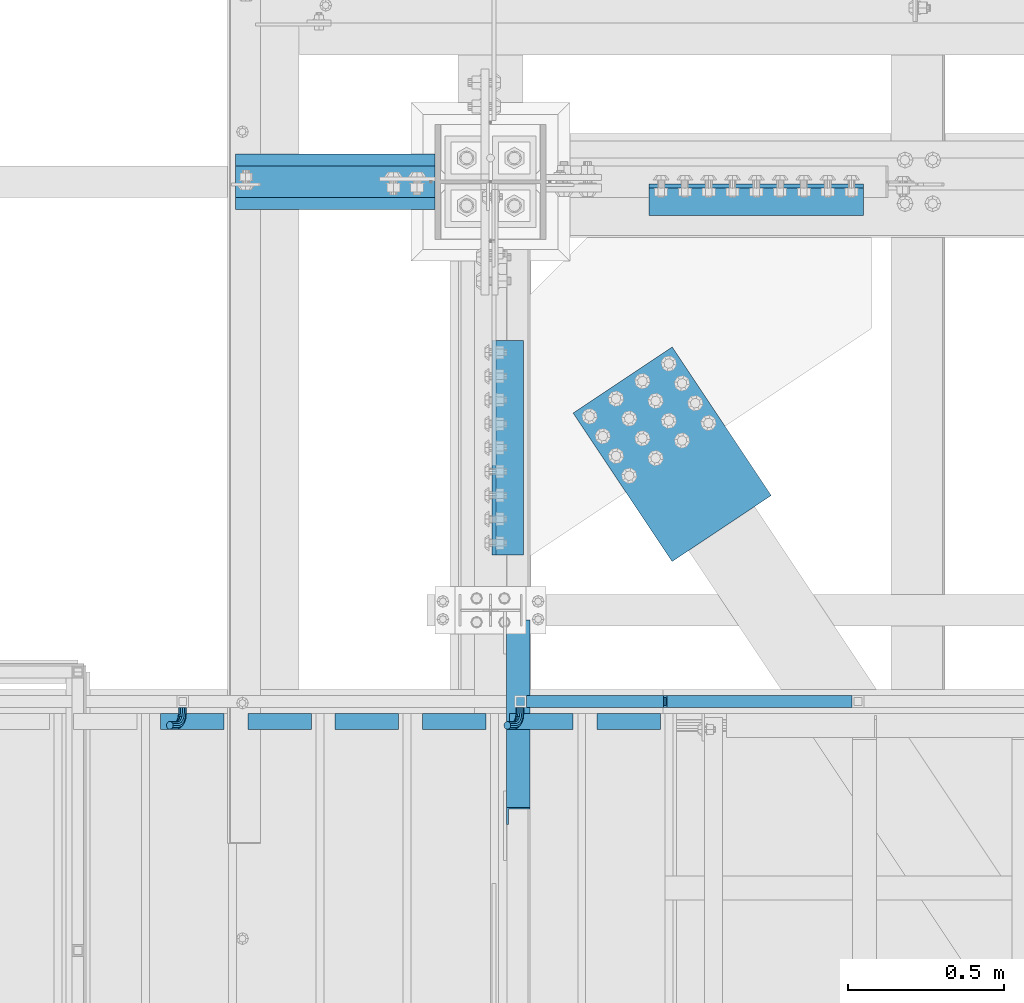
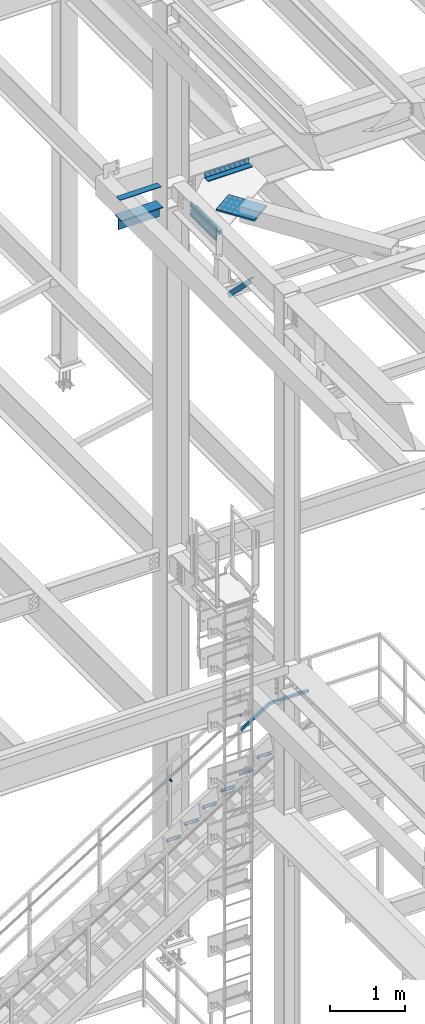
# One storey, part 2417 of 3843: 15 beams, 2 members, 7 elements without a shape of their own.
"""IFC2X3 building model written with IfcOpenShell, lengths in millimetres."""

from ifc_helpers import new_model, si_unit, frame, origin_with_axes, place, context, subcontext, project, spatial, faceted_brep, material, type_object, element, aggregate, save


model = new_model("IFC2X3")

# Units and contexts
model_context = context("Model", 3, precision=1e-05, world=origin_with_axes())
body_context = subcontext(model_context, "Body", "Model", "MODEL_VIEW")
ifc_project = project(units=[si_unit("LENGTHUNIT", "METRE", prefix="MILLI"), si_unit("AREAUNIT", "SQUARE_METRE"), si_unit("VOLUMEUNIT", "CUBIC_METRE"), si_unit("MASSUNIT", "GRAM", prefix="KILO"), si_unit("TIMEUNIT", "SECOND"), si_unit("PLANEANGLEUNIT", "RADIAN"), si_unit("SOLIDANGLEUNIT", "STERADIAN"), si_unit("THERMODYNAMICTEMPERATUREUNIT", "DEGREE_CELSIUS"), si_unit("LUMINOUSINTENSITYUNIT", "LUMEN")], contexts=[model_context])

# Site, building, storey
site_placement = place(None, origin_with_axes())
site = spatial("IfcSite", under=ifc_project, at=site_placement, CompositionType="ELEMENT")
building_placement = place(site_placement, origin_with_axes())
building = spatial("IfcBuilding", under=site, at=building_placement, Name="Undefined", CompositionType="ELEMENT")
storey_placement = place(building_placement, origin_with_axes())
storey = spatial("IfcBuildingStorey", under=building, at=storey_placement, Name="Undefined", CompositionType="ELEMENT", Elevation=0.0)

# Assembly, beam, member
assembly_1_placement = place(storey_placement, origin_with_axes())
assembly_1 = element("IfcElementAssembly", 1, at=assembly_1_placement, inside=storey, Name="RAIL", AssemblyPlace="NOTDEFINED", PredefinedType="RIGID_FRAME")
ifc_material_1 = material()
beam_type_1 = type_object("IfcBeamType", Name="HSS1-1/2X1-1/2X1/4", PredefinedType="NOTDEFINED")
beam_1_placement = place(assembly_1_placement, frame((37134.8000002412, 90551.0000000455, 34670.9999996949), z_axis=(0.0, 0.0, 1.0), x_axis=(1.0, 0.0, 0.0)))
beam_1 = element("IfcBeam", 2, at=beam_1_placement, type_object=beam_type_1, material=ifc_material_1, Name="RAIL", ObjectType="HSS1-1/2X1-1/2X1/4", context=body_context, shape_type="Brep", body=[
    faceted_brep([(598.714285670809, -19.0500000000029, 19.0499992350015), (598.714285670809, -19.0499992349942, -19.0499992350015), (598.714285670809, 19.0499992349942, -19.0499992350015), (598.714285670809, 19.0499992349942, 19.0499992350015), (598.714285670809, -12.6999993299978, 12.6999993299978), (598.714285670809, 12.6999993299978, 12.6999993299978), (598.714285670809, 12.6999993299978, -12.6999993299978), (598.714285670809, -12.6999993299978, -12.6999993299978), (-5.45142736178605, 19.0499992350015, 19.0499992350015), (-5.45142736178605, -19.0499992350015, 19.0499992350015), (5.45142728947758, -19.0499992350015, -19.0499992350015), (5.45142728947758, 19.0499992350015, -19.0499992350015), (-3.63428487412239, 12.6999993299978, 12.6999993299978), (-3.63428487412239, -12.6999993299978, 12.6999993299978), (3.63428480181392, -12.6999993299978, -12.6999993299978), (3.63428480181392, 12.6999993299978, -12.6999993299978)], [[[0, 1, 2, 3], [4, 5, 6, 7]], [[8, 9, 0, 3]], [[10, 11, 2, 1]], [[9, 10, 1, 0]], [[11, 8, 3, 2]], [[10, 9, 8, 11], [12, 13, 14, 15]], [[14, 13, 4, 7]], [[15, 14, 7, 6]], [[12, 15, 6, 5]], [[13, 12, 5, 4]]]),
])
member_type_1 = type_object("IfcMemberType", Name="HSS1-1/2X1-1/2X1/4", PredefinedType="NOTDEFINED")
member_1_placement = place(assembly_1_placement, frame((36671.7035715726, 90551.0000000455, 34382.3165117603), z_axis=(-0.529007926750979, 0.0, 0.848616882600523), x_axis=(0.848616882600527, 0.0, 0.529007926750974)))
member_1 = element("IfcMember", 3, at=member_1_placement, type_object=member_type_1, material=ifc_material_1, Name="RAIL", ObjectType="HSS1-1/2X1-1/2X1/4", context=body_context, shape_type="Brep", body=[
    faceted_brep([(34.3236166958304, -19.0500000222455, 19.0499992349305), (34.3236166958304, 19.0499992350015, 19.0499992349305), (10.5729683018217, 19.0499992350015, -19.0499992349742), (10.5729683018217, -19.0499992350015, -19.0499992349742), (30.3651751973375, -12.6999993299978, 12.6999993299451), (14.5314098008821, -12.6999993299978, -12.6999993299924), (14.5314098008821, 12.6999993299978, -12.6999993299924), (30.3651751973375, 12.6999993299978, 12.6999993299451), (540.255873788832, 19.0499992349942, -19.049999234514), (540.255873788832, -19.0499992349942, -19.049999234514), (551.158728464914, -19.0499992349942, 19.0499992354125), (551.158728464914, 19.0499992349942, 19.0499992354125), (549.341585973118, -12.6999993299978, 12.6999993304307), (549.341585973118, 12.6999993299978, 12.6999993304307), (542.073016280629, 12.6999993299978, -12.6999993295285), (542.073016280629, -12.6999993299978, -12.6999993295285)], [[[0, 1, 2, 3], [4, 5, 6, 7]], [[8, 9, 3, 2]], [[9, 10, 0, 3]], [[10, 11, 1, 0]], [[11, 8, 2, 1]], [[10, 9, 8, 11], [12, 13, 14, 15]], [[13, 12, 4, 7]], [[14, 13, 7, 6]], [[15, 14, 6, 5]], [[12, 15, 5, 4]]]),
])

# Assembly, beams
assembly_2_placement = place(storey_placement, origin_with_axes())
assembly_2 = element("IfcElementAssembly", 4, at=assembly_2_placement, inside=storey, Name="STAIR", AssemblyPlace="NOTDEFINED", PredefinedType="RIGID_FRAME")
ifc_material_2 = material(Name="STEEL/A36")
beam_type_2 = type_object("IfcBeamType", Name="L2X2X3/16", PredefinedType="NOTDEFINED")
beam_2_placement = place(assembly_2_placement, frame((36916.8169176754, 90487.500000018, 33884.0535714322), z_axis=(0.0, -1.0, 0.0), x_axis=(1.0, 0.0, 0.0)))
beam_2 = element("IfcBeam", 5, at=beam_2_placement, type_object=beam_type_2, material=ifc_material_2, Name="ANGLE", ObjectType="L2X2X3/16", context=body_context, shape_type="Brep", body=[
    faceted_brep([(0.0, 25.4000000000015, -25.4000000000015), (0.0, 25.4000000000015, 25.4000000000015), (203.199999999997, 25.4000000000015, 25.4000000000015), (203.199999999997, 25.4000000000015, -25.4000000000015), (0.0, 20.6375000000007, 25.4000000000015), (203.199999999997, 20.6375000000007, 25.4000000000015), (0.0, 20.6375000000007, -20.6375000000007), (203.199999999997, 20.6375000000007, -20.6375000000007), (0.0, -25.4000000000015, -20.6375000000007), (203.199999999997, -25.4000000000015, -20.6375000000007), (0.0, -25.4000000000015, -25.4000000000015), (203.199999999997, -25.4000000000015, -25.4000000000015)], [[[0, 1, 2, 3]], [[1, 4, 5, 2]], [[4, 6, 7, 5]], [[6, 8, 9, 7]], [[8, 10, 11, 9]], [[10, 0, 3, 11]], [[5, 7, 9, 11, 3, 2]], [[10, 8, 6, 4, 1, 0]]]),
])
beam_3_placement = place(assembly_2_placement, frame((36637.4169176732, 90487.4999999996, 33709.8821428615), z_axis=(0.0, -1.0, 0.0), x_axis=(1.0, 0.0, 0.0)))
beam_3 = element("IfcBeam", 6, at=beam_3_placement, type_object=beam_type_2, material=ifc_material_2, Name="ANGLE", ObjectType="L2X2X3/16", context=body_context, shape_type="Brep", body=[
    faceted_brep([(0.0, 25.4000000000015, -25.4000000000015), (0.0, 25.4000000000015, 25.4000000000015), (203.199999999997, 25.4000000000015, 25.4000000000015), (203.199999999997, 25.4000000000015, -25.4000000000015), (0.0, 20.6375000000007, 25.4000000000015), (203.199999999997, 20.6375000000007, 25.4000000000015), (0.0, 20.6375000000007, -20.6375000000007), (203.199999999997, 20.6375000000007, -20.6375000000007), (0.0, -25.4000000000015, -20.6375000000007), (203.199999999997, -25.4000000000015, -20.6375000000007), (0.0, -25.4000000000015, -25.4000000000015), (203.199999999997, -25.4000000000015, -25.4000000000015)], [[[0, 1, 2, 3]], [[1, 4, 5, 2]], [[4, 6, 7, 5]], [[6, 8, 9, 7]], [[8, 10, 11, 9]], [[10, 0, 3, 11]], [[5, 7, 9, 11, 3, 2]], [[10, 8, 6, 4, 1, 0]]]),
])
beam_4_placement = place(assembly_2_placement, frame((36358.0169176732, 90487.4999999996, 33535.71071429), z_axis=(0.0, -1.0, 0.0), x_axis=(1.0, 0.0, 0.0)))
beam_4 = element("IfcBeam", 7, at=beam_4_placement, type_object=beam_type_2, material=ifc_material_2, Name="ANGLE", ObjectType="L2X2X3/16", context=body_context, shape_type="Brep", body=[
    faceted_brep([(0.0, 25.4000000000015, -25.4000000000015), (0.0, 25.4000000000015, 25.4000000000015), (203.199999999997, 25.4000000000015, 25.4000000000015), (203.199999999997, 25.4000000000015, -25.4000000000015), (0.0, 20.6375000000007, 25.4000000000015), (203.199999999997, 20.6375000000007, 25.4000000000015), (0.0, 20.6375000000007, -20.6375000000007), (203.199999999997, 20.6375000000007, -20.6375000000007), (0.0, -25.4000000000015, -20.6375000000007), (203.199999999997, -25.4000000000015, -20.6375000000007), (0.0, -25.4000000000015, -25.4000000000015), (203.199999999997, -25.4000000000015, -25.4000000000015)], [[[0, 1, 2, 3]], [[1, 4, 5, 2]], [[4, 6, 7, 5]], [[6, 8, 9, 7]], [[8, 10, 11, 9]], [[10, 0, 3, 11]], [[5, 7, 9, 11, 3, 2]], [[10, 8, 6, 4, 1, 0]]]),
])
beam_5_placement = place(assembly_2_placement, frame((36078.6169176732, 90487.4999999996, 33361.5392857186), z_axis=(0.0, -1.0, 0.0), x_axis=(1.0, 0.0, 0.0)))
beam_5 = element("IfcBeam", 8, at=beam_5_placement, type_object=beam_type_2, material=ifc_material_2, Name="ANGLE", ObjectType="L2X2X3/16", context=body_context, shape_type="Brep", body=[
    faceted_brep([(0.0, 25.4000000000015, -25.4000000000015), (0.0, 25.4000000000015, 25.4000000000015), (203.199999999997, 25.4000000000015, 25.4000000000015), (203.199999999997, 25.4000000000015, -25.4000000000015), (0.0, 20.6375000000007, 25.4000000000015), (203.199999999997, 20.6375000000007, 25.4000000000015), (0.0, 20.6375000000007, -20.6375000000007), (203.199999999997, 20.6375000000007, -20.6375000000007), (0.0, -25.4000000000015, -20.6375000000007), (203.199999999997, -25.4000000000015, -20.6375000000007), (0.0, -25.4000000000015, -25.4000000000015), (203.199999999997, -25.4000000000015, -25.4000000000015)], [[[0, 1, 2, 3]], [[1, 4, 5, 2]], [[4, 6, 7, 5]], [[6, 8, 9, 7]], [[8, 10, 11, 9]], [[10, 0, 3, 11]], [[5, 7, 9, 11, 3, 2]], [[10, 8, 6, 4, 1, 0]]]),
])
beam_6_placement = place(assembly_2_placement, frame((35799.2169176732, 90487.4999999996, 33187.3678571472), z_axis=(0.0, -1.0, 0.0), x_axis=(1.0, 0.0, 0.0)))
beam_6 = element("IfcBeam", 9, at=beam_6_placement, type_object=beam_type_2, material=ifc_material_2, Name="ANGLE", ObjectType="L2X2X3/16", context=body_context, shape_type="Brep", body=[
    faceted_brep([(0.0, 25.4000000000015, -25.4000000000015), (0.0, 25.4000000000015, 25.4000000000015), (203.199999999997, 25.4000000000015, 25.4000000000015), (203.199999999997, 25.4000000000015, -25.4000000000015), (0.0, 20.6375000000007, 25.4000000000015), (203.199999999997, 20.6375000000007, 25.4000000000015), (0.0, 20.6375000000007, -20.6375000000007), (203.199999999997, 20.6375000000007, -20.6375000000007), (0.0, -25.4000000000015, -20.6375000000007), (203.199999999997, -25.4000000000015, -20.6375000000007), (0.0, -25.4000000000015, -25.4000000000015), (203.199999999997, -25.4000000000015, -25.4000000000015)], [[[0, 1, 2, 3]], [[1, 4, 5, 2]], [[4, 6, 7, 5]], [[6, 8, 9, 7]], [[8, 10, 11, 9]], [[10, 0, 3, 11]], [[5, 7, 9, 11, 3, 2]], [[10, 8, 6, 4, 1, 0]]]),
])
beam_7_placement = place(assembly_2_placement, frame((35519.8169176732, 90487.4999999996, 33013.1964285758), z_axis=(0.0, -1.0, 0.0), x_axis=(1.0, 0.0, 0.0)))
beam_7 = element("IfcBeam", 10, at=beam_7_placement, type_object=beam_type_2, material=ifc_material_2, Name="ANGLE", ObjectType="L2X2X3/16", context=body_context, shape_type="Brep", body=[
    faceted_brep([(0.0, 25.4000000000015, -25.4000000000015), (0.0, 25.4000000000015, 25.4000000000015), (203.199999999997, 25.4000000000015, 25.4000000000015), (203.199999999997, 25.4000000000015, -25.4000000000015), (0.0, 20.6375000000007, 25.4000000000015), (203.199999999997, 20.6375000000007, 25.4000000000015), (0.0, 20.6375000000007, -20.6375000000007), (203.199999999997, 20.6375000000007, -20.6375000000007), (0.0, -25.4000000000015, -20.6375000000007), (203.199999999997, -25.4000000000015, -20.6375000000007), (0.0, -25.4000000000015, -25.4000000000015), (203.199999999997, -25.4000000000015, -25.4000000000015)], [[[0, 1, 2, 3]], [[1, 4, 5, 2]], [[4, 6, 7, 5]], [[6, 8, 9, 7]], [[8, 10, 11, 9]], [[10, 0, 3, 11]], [[5, 7, 9, 11, 3, 2]], [[10, 8, 6, 4, 1, 0]]]),
])
aggregate(assembly_2, [beam_2, beam_3, beam_4, beam_5, beam_6, beam_7])

# Assembly, beam
assembly_3_placement = place(storey_placement, origin_with_axes())
assembly_3 = element("IfcElementAssembly", 11, at=assembly_3_placement, inside=storey, Name="COLUMN", AssemblyPlace="NOTDEFINED", PredefinedType="RIGID_FRAME")
ifc_material_3 = material(Name="STEEL/A992")
beam_type_3 = type_object("IfcBeamType", Name="WT8X18", PredefinedType="NOTDEFINED")
beam_8_placement = place(assembly_3_placement, frame((35760.025, 92214.7, 41962.3875), z_axis=(0.0, 0.0, 1.0), x_axis=(1.0, 0.0, 0.0)))
beam_8 = element("IfcBeam", 12, at=beam_8_placement, type_object=beam_type_3, material=ifc_material_3, Name="BEAM", ObjectType="WT8X18", context=body_context, shape_type="Brep", body=[
    faceted_brep([(-1.45519152283669e-11, 3.96875, -100.012499999997), (-1.45519152283669e-11, 3.96875, 88.9000000000015), (638.175000000003, 3.96875, 88.9000000000015), (638.175000000003, 3.96875, -100.012499999997), (-2.18278728425503e-10, 88.8999999999942, 88.9000000000015), (638.175000000003, 88.9000000000015, 88.9000000000015), (-2.18278728425503e-10, 88.8999999999942, 100.012499999997), (638.175000000003, 88.9000000000015, 100.012499999997), (2.03726813197136e-10, -88.8999999999942, 100.012499999997), (638.175000000003, -88.9000000000015, 100.012499999997), (2.03726813197136e-10, -88.8999999999942, 88.9000000000015), (638.175000000003, -88.9000000000015, 88.9000000000015), (0.0, -3.96875, 88.9000000000015), (638.175000000003, -3.96875, 88.9000000000015), (0.0, -3.96875, -100.012499999997), (638.175000000003, -3.96875, -100.012499999997)], [[[0, 1, 2, 3]], [[1, 4, 5, 2]], [[4, 6, 7, 5]], [[6, 8, 9, 7]], [[8, 10, 11, 9]], [[10, 12, 13, 11]], [[12, 14, 15, 13]], [[14, 0, 3, 15]], [[5, 7, 9, 11, 13, 15, 3, 2]], [[14, 12, 10, 8, 6, 4, 1, 0]]]),
])
aggregate(assembly_3, [beam_8])

# Beam
beam_type_4 = type_object("IfcBeamType", PredefinedType="NOTDEFINED")
beam_9_placement = place(assembly_1_placement, frame((36670.1313687495, 90531.9500000455, 34650.0949745017), z_axis=(-0.848616882600527, 0.0, -0.529007926750974), x_axis=(0.0, -1.0, 0.0)))
beam_9 = element("IfcBeam", 13, at=beam_9_placement, type_object=beam_type_4, material=ifc_material_2, Name="BRACKET ARM", context=body_context, shape_type="Brep", body=[
    faceted_brep([(0.0, -12.6999999999971, 0.0), (0.0, -10.9985226280696, -6.34999999999854), (19.0500015258731, -10.9985226280623, -6.34999999999854), (19.0500015258731, -12.6999999999971, -6.33008312433958e-10), (0.0, -6.35000000000582, -10.9985226280623), (19.0500015258731, -6.34999999999854, -10.9985226280623), (0.0, 0.0, -12.6999999999971), (19.0500015258731, 0.0, -12.6999999999971), (0.0, 6.35000000000582, -10.9985226280623), (19.0500015258731, 6.34999999999854, -10.9985226280623), (0.0, 10.9985226280696, -6.34999999999854), (19.0500015258731, 10.9985226280623, -6.34999999999854), (0.0, 12.6999999999971, 0.0), (19.0500015258731, 12.6999999999971, 0.0), (0.0, 10.9985226280696, 6.34999999999854), (19.0500015258731, 10.9985226280623, 6.34999999999854), (0.0, 6.35000000000582, 10.9985226280623), (19.0500015258731, 6.34999999999854, 10.9985226280623), (0.0, 0.0, 12.6999999999971), (19.0500015258731, 0.0, 12.6999999999971), (0.0, -6.35000000000582, 10.9985226280623), (19.0500015258731, -6.34999999999854, 10.9985226280623), (0.0, -10.9985226280696, 6.34999999999854), (19.0500015258731, -10.9985226280623, 6.34999999999854), (38.4903193060891, -8.8330803677236, -3.34694050252438e-10), (37.8391921052389, -7.26112024908798, 6.34999999974389), (36.0602795104642, -2.96644533684594, 10.9985226280041), (33.6302397149266, 2.90018969451194, 12.7000000002226), (31.2001999194181, 8.76682472604443, 10.9985226285644), (29.4212873247307, 13.061499638774, 6.35000000070431), (28.7701601240115, 14.6334597580644, 7.78527464717627e-10), (29.4212873248762, 13.0614996394288, -6.34999999929278), (31.2001999196509, 8.76682472718676, -10.9985226275603), (33.6302397151885, 2.90018969582889, -12.6999999997788), (36.0602795106824, -2.96644533571089, -10.9985226281206), (37.8391921053699, -7.26112024843314, -6.35000000026048), (53.7678987435793, 3.38210125690239, -6.3499999994383), (54.9710249311902, 2.17897506880399, 5.0931703299284e-10), (50.4808968708676, 6.66910312997061, -10.9985226273784), (45.9907688103704, 11.1592311906061, -12.6999999991458), (41.5006407498004, 15.6493592510378, -10.9985226270364), (38.213638876914, 18.9363611235749, -6.34999999884167), (37.0105126890558, 20.1394873109457, 1.20053300634027e-09), (38.2136388766667, 18.9363611228473, 6.35000000115542), (41.5006407493784, 15.6493592497718, 10.9985226290883), (45.9907688098756, 11.1592311891436, 12.7000000008557), (50.4808968704456, 6.66910312870459, 10.9985226287463), (53.7678987433319, 3.38210125617479, 6.35000000055879), (64.4111202489148, 19.3108078951118, -6.34999999821594), (65.9830803677178, 18.6596806939051, 1.77533365786076e-09), (60.1164453365491, 21.0897204901557, -10.9985226262725), (54.2498103051475, 23.5197602857806, -12.6999999981927), (48.3831752736587, 25.9498000811873, -10.9985226262434), (44.0885003610601, 27.7287126756128, -6.34999999817228), (42.516540241937, 28.3798398759754, 1.83354131877422e-09), (44.08850036074, 27.7287126747688, 6.35000000183209), (48.3831752731057, 25.9498000797321, 10.9985226298813), (54.2498103045073, 23.5197602840999, 12.7000000018088), (60.1164453359961, 21.0897204886933, 10.9985226298522), (64.4111202485947, 19.3108078942678, 6.35000000178115), (68.1485226282239, 38.0999984746086, -6.3499999967753), (69.8499999999913, 38.0999984741211, 2.92493496090174e-09), (63.500000000291, 38.0999984749651, -10.9985226249628), (57.1500000003434, 38.0999984750961, -12.6999999970722), (50.8000000002939, 38.0999984749651, -10.998522625312), (46.1514773720992, 38.0999984746086, -6.34999999737192), (44.4499999999971, 38.0999984741211, 2.58296495303512e-09), (46.1514773717645, 38.0999984736336, 6.35000000262517), (50.7999999996973, 38.0999984732771, 10.9985226308127), (57.1499999996449, 38.0999984731461, 12.700000002922), (63.4999999996944, 38.0999984732771, 10.9985226311619), (68.1485226278892, 38.0999984736336, 6.35000000322179), (68.1485226280638, 76.2000000002372, -6.34999999414867), (69.8499999999913, 76.199999999757, 5.84986992180347e-09), (63.5, 76.200000000601, -10.9985226222125), (57.1499999999942, 76.2000000007247, -12.6999999941472), (50.7999999999884, 76.200000000601, -10.9985226222125), (46.1514773719246, 76.2000000002372, -6.34999999414867), (44.4499999999971, 76.199999999757, 5.84986992180347e-09), (46.1514773719246, 76.1999999992695, 6.35000000584841), (50.7999999999884, 76.1999999989057, 10.9985226339122), (57.1499999999942, 76.199999998782, 12.700000005847), (63.5, 76.1999999989057, 10.9985226339122), (68.1485226280638, 76.1999999992695, 6.35000000584841)], [[[0, 1, 2, 3]], [[1, 4, 5, 2]], [[4, 6, 7, 5]], [[6, 8, 9, 7]], [[8, 10, 11, 9]], [[10, 12, 13, 11]], [[12, 14, 15, 13]], [[14, 16, 17, 15]], [[16, 18, 19, 17]], [[18, 20, 21, 19]], [[20, 22, 23, 21]], [[22, 0, 3, 23]], [[22, 20, 18, 16, 14, 12, 10, 8, 6, 4, 1, 0]], [[23, 3, 24, 25]], [[21, 23, 25, 26]], [[19, 21, 26, 27]], [[17, 19, 27, 28]], [[15, 17, 28, 29]], [[13, 15, 29, 30]], [[11, 13, 30, 31]], [[9, 11, 31, 32]], [[7, 9, 32, 33]], [[5, 7, 33, 34]], [[2, 5, 34, 35]], [[3, 2, 35, 24]], [[35, 36, 37, 24]], [[34, 38, 36, 35]], [[33, 39, 38, 34]], [[32, 40, 39, 33]], [[31, 41, 40, 32]], [[30, 42, 41, 31]], [[29, 43, 42, 30]], [[28, 44, 43, 29]], [[27, 45, 44, 28]], [[26, 46, 45, 27]], [[25, 47, 46, 26]], [[24, 37, 47, 25]], [[36, 48, 49, 37]], [[38, 50, 48, 36]], [[39, 51, 50, 38]], [[40, 52, 51, 39]], [[41, 53, 52, 40]], [[42, 54, 53, 41]], [[43, 55, 54, 42]], [[44, 56, 55, 43]], [[45, 57, 56, 44]], [[46, 58, 57, 45]], [[47, 59, 58, 46]], [[37, 49, 59, 47]], [[48, 60, 61, 49]], [[50, 62, 60, 48]], [[51, 63, 62, 50]], [[52, 64, 63, 51]], [[53, 65, 64, 52]], [[54, 66, 65, 53]], [[55, 67, 66, 54]], [[56, 68, 67, 55]], [[57, 69, 68, 56]], [[58, 70, 69, 57]], [[59, 71, 70, 58]], [[49, 61, 71, 59]], [[61, 60, 72, 73]], [[60, 62, 74, 72]], [[62, 63, 75, 74]], [[63, 64, 76, 75]], [[64, 65, 77, 76]], [[65, 66, 78, 77]], [[66, 67, 79, 78]], [[67, 68, 80, 79]], [[68, 69, 81, 80]], [[69, 70, 82, 81]], [[70, 71, 83, 82]], [[71, 61, 73, 83]], [[74, 75, 76, 77, 78, 79, 80, 81, 82, 83, 73, 72]]]),
])

beam_10_placement = place(assembly_1_placement, frame((35589.6935693092, 90531.9500000455, 33976.5753072845), z_axis=(-0.848616882600527, 0.0, -0.529007926750974), x_axis=(0.0, -1.0, 0.0)))
beam_10 = element("IfcBeam", 14, at=beam_10_placement, type_object=beam_type_4, material=ifc_material_2, Name="BRACKET ARM", context=body_context, shape_type="Brep", body=[
    faceted_brep([(0.0, -12.6999999999971, 0.0), (0.0, -10.9985226280696, -6.34999999999854), (19.0500015258731, -10.9985226280623, -6.34999999999854), (19.0500015258731, -12.6999999999971, -6.33008312433958e-10), (0.0, -6.35000000000582, -10.9985226280623), (19.0500015258731, -6.34999999999854, -10.9985226280623), (0.0, 0.0, -12.6999999999971), (19.0500015258731, 0.0, -12.6999999999971), (0.0, 6.35000000000582, -10.9985226280623), (19.0500015258731, 6.34999999999854, -10.9985226280623), (0.0, 10.9985226280696, -6.34999999999854), (19.0500015258731, 10.9985226280623, -6.34999999999854), (0.0, 12.6999999999971, 0.0), (19.0500015258731, 12.6999999999971, 0.0), (0.0, 10.9985226280696, 6.34999999999854), (19.0500015258731, 10.9985226280623, 6.34999999999854), (0.0, 6.35000000000582, 10.9985226280623), (19.0500015258731, 6.34999999999854, 10.9985226280623), (0.0, 0.0, 12.6999999999971), (19.0500015258731, 0.0, 12.6999999999971), (0.0, -6.35000000000582, 10.9985226280623), (19.0500015258731, -6.34999999999854, 10.9985226280623), (0.0, -10.9985226280696, 6.34999999999854), (19.0500015258731, -10.9985226280623, 6.34999999999854), (38.4903193060891, -8.8330803677236, -3.34694050252438e-10), (37.8391921052389, -7.26112024908798, 6.34999999974389), (36.0602795104642, -2.96644533684594, 10.9985226280041), (33.6302397149266, 2.90018969451194, 12.7000000002226), (31.2001999194181, 8.76682472604443, 10.9985226285644), (29.4212873247307, 13.061499638774, 6.35000000070431), (28.7701601240115, 14.6334597580644, 7.78527464717627e-10), (29.4212873248762, 13.0614996394288, -6.34999999929278), (31.2001999196509, 8.76682472718676, -10.9985226275603), (33.6302397151885, 2.90018969582889, -12.6999999997788), (36.0602795106824, -2.96644533571089, -10.9985226281206), (37.8391921053699, -7.26112024843314, -6.35000000026048), (53.7678987435793, 3.38210125690239, -6.3499999994383), (54.9710249311902, 2.17897506880399, 5.0931703299284e-10), (50.4808968708676, 6.66910312997061, -10.9985226273784), (45.9907688103704, 11.1592311906061, -12.6999999991458), (41.5006407498004, 15.6493592510378, -10.9985226270364), (38.213638876914, 18.9363611235749, -6.34999999884167), (37.0105126890558, 20.1394873109457, 1.20053300634027e-09), (38.2136388766667, 18.9363611228473, 6.35000000115542), (41.5006407493784, 15.6493592497718, 10.9985226290883), (45.9907688098756, 11.1592311891436, 12.7000000008557), (50.4808968704456, 6.66910312870459, 10.9985226287463), (53.7678987433319, 3.38210125617479, 6.35000000055879), (64.4111202489148, 19.3108078951118, -6.34999999821594), (65.9830803677178, 18.6596806939051, 1.77533365786076e-09), (60.1164453365491, 21.0897204901557, -10.9985226262725), (54.2498103051475, 23.5197602857806, -12.6999999981927), (48.3831752736587, 25.9498000811873, -10.9985226262434), (44.0885003610601, 27.7287126756128, -6.34999999817228), (42.516540241937, 28.3798398759754, 1.83354131877422e-09), (44.08850036074, 27.7287126747688, 6.35000000183209), (48.3831752731057, 25.9498000797321, 10.9985226298813), (54.2498103045073, 23.5197602840999, 12.7000000018088), (60.1164453359961, 21.0897204886933, 10.9985226298522), (64.4111202485947, 19.3108078942678, 6.35000000178115), (68.1485226282239, 38.0999984746086, -6.3499999967753), (69.8499999999913, 38.0999984741211, 2.92493496090174e-09), (63.500000000291, 38.0999984749651, -10.9985226249628), (57.1500000003434, 38.0999984750961, -12.6999999970722), (50.8000000002939, 38.0999984749651, -10.998522625312), (46.1514773720992, 38.0999984746086, -6.34999999737192), (44.4499999999971, 38.0999984741211, 2.58296495303512e-09), (46.1514773717645, 38.0999984736336, 6.35000000262517), (50.7999999996973, 38.0999984732771, 10.9985226308127), (57.1499999996449, 38.0999984731461, 12.700000002922), (63.4999999996944, 38.0999984732771, 10.9985226311619), (68.1485226278892, 38.0999984736336, 6.35000000322179), (68.1485226280638, 76.2000000002372, -6.34999999414867), (69.8499999999913, 76.199999999757, 5.84986992180347e-09), (63.5, 76.200000000601, -10.9985226222125), (57.1499999999942, 76.2000000007247, -12.6999999941472), (50.7999999999884, 76.200000000601, -10.9985226222125), (46.1514773719246, 76.2000000002372, -6.34999999414867), (44.4499999999971, 76.199999999757, 5.84986992180347e-09), (46.1514773719246, 76.1999999992695, 6.35000000584841), (50.7999999999884, 76.1999999989057, 10.9985226339122), (57.1499999999942, 76.199999998782, 12.700000005847), (63.5, 76.1999999989057, 10.9985226339122), (68.1485226280638, 76.1999999992695, 6.35000000584841)], [[[0, 1, 2, 3]], [[1, 4, 5, 2]], [[4, 6, 7, 5]], [[6, 8, 9, 7]], [[8, 10, 11, 9]], [[10, 12, 13, 11]], [[12, 14, 15, 13]], [[14, 16, 17, 15]], [[16, 18, 19, 17]], [[18, 20, 21, 19]], [[20, 22, 23, 21]], [[22, 0, 3, 23]], [[22, 20, 18, 16, 14, 12, 10, 8, 6, 4, 1, 0]], [[23, 3, 24, 25]], [[21, 23, 25, 26]], [[19, 21, 26, 27]], [[17, 19, 27, 28]], [[15, 17, 28, 29]], [[13, 15, 29, 30]], [[11, 13, 30, 31]], [[9, 11, 31, 32]], [[7, 9, 32, 33]], [[5, 7, 33, 34]], [[2, 5, 34, 35]], [[3, 2, 35, 24]], [[35, 36, 37, 24]], [[34, 38, 36, 35]], [[33, 39, 38, 34]], [[32, 40, 39, 33]], [[31, 41, 40, 32]], [[30, 42, 41, 31]], [[29, 43, 42, 30]], [[28, 44, 43, 29]], [[27, 45, 44, 28]], [[26, 46, 45, 27]], [[25, 47, 46, 26]], [[24, 37, 47, 25]], [[36, 48, 49, 37]], [[38, 50, 48, 36]], [[39, 51, 50, 38]], [[40, 52, 51, 39]], [[41, 53, 52, 40]], [[42, 54, 53, 41]], [[43, 55, 54, 42]], [[44, 56, 55, 43]], [[45, 57, 56, 44]], [[46, 58, 57, 45]], [[47, 59, 58, 46]], [[37, 49, 59, 47]], [[48, 60, 61, 49]], [[50, 62, 60, 48]], [[51, 63, 62, 50]], [[52, 64, 63, 51]], [[53, 65, 64, 52]], [[54, 66, 65, 53]], [[55, 67, 66, 54]], [[56, 68, 67, 55]], [[57, 69, 68, 56]], [[58, 70, 69, 57]], [[59, 71, 70, 58]], [[49, 61, 71, 59]], [[61, 60, 72, 73]], [[60, 62, 74, 72]], [[62, 63, 75, 74]], [[63, 64, 76, 75]], [[64, 65, 77, 76]], [[65, 66, 78, 77]], [[66, 67, 79, 78]], [[67, 68, 80, 79]], [[68, 69, 81, 80]], [[69, 70, 82, 81]], [[70, 71, 83, 82]], [[71, 61, 73, 83]], [[74, 75, 76, 77, 78, 79, 80, 81, 82, 83, 73, 72]]]),
])

aggregate(assembly_1, [beam_9, beam_10, beam_1, member_1])

# Assembly, beam
assembly_4_placement = place(storey_placement, origin_with_axes())
assembly_4 = element("IfcElementAssembly", 15, at=assembly_4_placement, inside=storey, Name="PLATE", AssemblyPlace="NOTDEFINED", PredefinedType="RIGID_FRAME")
ifc_material_4 = material(Name="STEEL/A572-50")
beam_type_5 = type_object("IfcBeamType", PredefinedType="NOTDEFINED")
beam_11_placement = place(assembly_4_placement, frame((35760.025, 92214.7, 42371.9625), z_axis=(0.0, 1.0, 0.0), x_axis=(1.0, 0.0, 0.0)))
beam_11 = element("IfcBeam", 16, at=beam_11_placement, type_object=beam_type_5, material=ifc_material_4, Name="PLATE", context=body_context, shape_type="Brep", body=[
    faceted_brep([(0.0, 4.76249999999709, -50.7999999999993), (0.0, 4.76249999999709, 50.7999999999993), (638.175000000003, 4.76249999999709, 50.7999999999993), (638.175000000003, 4.76249999999709, -50.7999999999993), (0.0, -4.76249999999709, 50.7999999999993), (638.175000000003, -4.76249999999709, 50.7999999999993), (0.0, -4.76249999999709, -50.7999999999993), (638.175000000003, -4.76249999999709, -50.7999999999993)], [[[0, 1, 2, 3]], [[1, 4, 5, 2]], [[4, 6, 7, 5]], [[6, 0, 3, 7]], [[5, 7, 3, 2]], [[6, 4, 1, 0]]]),
])
aggregate(assembly_4, [beam_11])

# Assembly, beams
assembly_5_placement = place(storey_placement, origin_with_axes())
assembly_5 = element("IfcElementAssembly", 17, at=assembly_5_placement, inside=storey, Name="PLATE", AssemblyPlace="NOTDEFINED", PredefinedType="RIGID_FRAME")
beam_type_6 = type_object("IfcBeamType", Name="L4X4X1/2", PredefinedType="NOTDEFINED")
beam_12_placement = place(assembly_5_placement, frame((37769.8, 92157.5500000008, 42297.35), z_axis=(0.0, -1.0, 0.0), x_axis=(-1.0, 0.0, 0.0)))
beam_12 = element("IfcBeam", 18, at=beam_12_placement, type_object=beam_type_6, material=ifc_material_4, Name="ANGLE", ObjectType="L4X4X1/2", context=body_context, shape_type="Brep", body=[
    faceted_brep([(0.0, 50.8000000000029, -50.8000000000029), (0.0, 50.8000000000029, 50.8000000000029), (685.800000000003, 50.8000000000029, 50.8000000000029), (685.800000000003, 50.8000000000029, -50.8000000000029), (0.0, 38.0999999999985, 50.8000000000029), (685.800000000003, 38.0999999999985, 50.8000000000029), (0.0, 38.0999999999985, -38.0999999999985), (685.800000000003, 38.0999999999985, -38.1000000000058), (0.0, -50.8000000000029, -38.1000000000058), (685.800000000003, -50.8000000000029, -38.1000000000058), (0.0, -50.8000000000029, -50.8000000000029), (685.800000000003, -50.8000000000029, -50.8000000000029)], [[[0, 1, 2, 3]], [[1, 4, 5, 2]], [[4, 6, 7, 5]], [[6, 8, 9, 7]], [[8, 10, 11, 9]], [[10, 0, 3, 11]], [[5, 7, 9, 11, 3, 2]], [[10, 8, 6, 4, 1, 0]]]),
])
beam_13_placement = place(assembly_5_placement, frame((36631.5625000004, 91706.7, 42297.35), z_axis=(1.0, 0.0, 0.0), x_axis=(0.0, -1.0, 0.0)))
beam_13 = element("IfcBeam", 19, at=beam_13_placement, type_object=beam_type_6, material=ifc_material_4, Name="ANGLE", ObjectType="L4X4X1/2", context=body_context, shape_type="Brep", body=[
    faceted_brep([(0.0, 50.8000000000029, -50.8000000000029), (0.0, 50.8000000000029, 50.8000000000029), (685.800000000003, 50.8000000000029, 50.8000000000029), (685.800000000003, 50.8000000000029, -50.8000000000029), (0.0, 38.0999999999985, 50.8000000000029), (685.800000000003, 38.0999999999985, 50.8000000000029), (0.0, 38.0999999999985, -38.0999999999985), (685.800000000003, 38.0999999999985, -38.1000000000058), (0.0, -50.8000000000029, -38.1000000000058), (685.800000000003, -50.8000000000029, -38.1000000000058), (0.0, -50.8000000000029, -50.8000000000029), (685.800000000003, -50.8000000000029, -50.8000000000029)], [[[0, 1, 2, 3]], [[1, 4, 5, 2]], [[4, 6, 7, 5]], [[6, 8, 9, 7]], [[8, 10, 11, 9]], [[10, 0, 3, 11]], [[5, 7, 9, 11, 3, 2]], [[10, 8, 6, 4, 1, 0]]]),
])
beam_14_placement = place(assembly_5_placement, frame((36631.5625000004, 91020.9, 42167.175), z_axis=(1.0, 0.0, 0.0), x_axis=(0.0, 1.0, 0.0)))
beam_14 = element("IfcBeam", 20, at=beam_14_placement, type_object=beam_type_6, material=ifc_material_4, Name="ANGLE", ObjectType="L4X4X1/2", context=body_context, shape_type="Brep", body=[
    faceted_brep([(0.0, 50.8000000000029, -50.8000000000029), (0.0, 50.8000000000029, 50.8000000000029), (685.800000000003, 50.8000000000029, 50.8000000000029), (685.800000000003, 50.8000000000029, -50.8000000000029), (0.0, 38.0999999999985, 50.8000000000029), (685.800000000003, 38.0999999999985, 50.8000000000029), (0.0, 38.0999999999985, -38.0999999999985), (685.800000000003, 38.0999999999985, -38.1000000000058), (0.0, -50.8000000000029, -38.1000000000058), (685.800000000003, -50.8000000000029, -38.1000000000058), (0.0, -50.8000000000029, -50.8000000000029), (685.800000000003, -50.8000000000029, -50.8000000000029)], [[[0, 1, 2, 3]], [[1, 4, 5, 2]], [[4, 6, 7, 5]], [[6, 8, 9, 7]], [[8, 10, 11, 9]], [[10, 0, 3, 11]], [[5, 7, 9, 11, 3, 2]], [[10, 8, 6, 4, 1, 0]]]),
])
aggregate(assembly_5, [beam_12, beam_13, beam_14])

# Assembly, member
assembly_6_placement = place(storey_placement, origin_with_axes())
assembly_6 = element("IfcElementAssembly", 21, at=assembly_6_placement, inside=storey, Name="ANGLE", AssemblyPlace="NOTDEFINED", PredefinedType="RIGID_FRAME")
member_type_2 = type_object("IfcMemberType", Name="L3X3X1/4", PredefinedType="NOTDEFINED")
member_2_placement = place(assembly_6_placement, frame((36664.9, 90843.1, 41300.4), z_axis=(0.0, -0.707106781186548, -0.707106781186548), x_axis=(0.0, -0.707106781186682, 0.707106781186413)))
member_2 = element("IfcMember", 22, at=member_2_placement, type_object=member_type_2, material=ifc_material_4, Name="ANGLE", ObjectType="L3X3X1/4", context=body_context, shape_type="Brep", body=[
    faceted_brep([(83.0012806675732, 38.0999999999985, -38.0999999999058), (83.0012806675732, -38.0999999999985, -38.0999999999058), (83.0012806675804, -38.0999999999985, -31.7499999999254), (83.0012806675804, 31.75, -31.7499999999254), (83.0012806675804, 31.75, 38.0999999999058), (83.0012806675804, 38.0999999999985, 38.0999999999058), (931.76766108568, 31.75, 38.1000000048953), (931.76766108568, 38.0999999999985, 38.1000000048953), (931.767661084901, 38.0999999999985, -38.0999999953056), (931.767661084901, -38.0999999999985, -38.0999999953056), (931.767661084959, -38.0999999999985, -31.7499999952997), (931.767661084959, 31.75, -31.7499999952997)], [[[0, 1, 2, 3, 4, 5]], [[5, 4, 6, 7]], [[0, 5, 7, 8]], [[1, 0, 8, 9]], [[2, 1, 9, 10]], [[3, 2, 10, 11]], [[4, 3, 11, 6]], [[10, 9, 8, 7, 6, 11]]]),
])
aggregate(assembly_6, [member_2])

# Assembly, beam
assembly_7_placement = place(storey_placement, origin_with_axes())
assembly_7 = element("IfcElementAssembly", 23, at=assembly_7_placement, inside=storey, AssemblyPlace="NOTDEFINED", PredefinedType="RIGID_FRAME")
beam_type_7 = type_object("IfcBeamType", PredefinedType="NOTDEFINED")
beam_15_placement = place(assembly_7_placement, frame((36998.9427648042, 91580.2858527937, 42259.25), z_axis=(-0.832050294337846, -0.554700196225226, 0.0), x_axis=(0.55470019622522, -0.83205029433785, 0.0)))
beam_15 = element("IfcBeam", 24, at=beam_15_placement, type_object=beam_type_7, material=ifc_material_4, Name="PLATE", context=body_context, shape_type="Brep", body=[
    faceted_brep([(5.85714587941766e-10, 12.6999999999971, -190.500000000349), (-6.14818418398499e-10, 12.6999999999971, 190.500000000364), (571.499999996191, 12.6999999999971, 190.49999999936), (571.499999997392, 12.6999999999971, -190.500000001353), (-6.14818418398499e-10, -12.6999999999971, 190.500000000364), (571.499999996191, -12.6999999999971, 190.49999999936), (5.85714587941766e-10, -12.6999999999971, -190.500000000349), (571.499999997392, -12.6999999999971, -190.500000001353)], [[[0, 1, 2, 3]], [[1, 4, 5, 2]], [[4, 6, 7, 5]], [[6, 0, 3, 7]], [[5, 7, 3, 2]], [[6, 4, 1, 0]]]),
])
aggregate(assembly_7, [beam_15])

save(model, "model.ifc")
